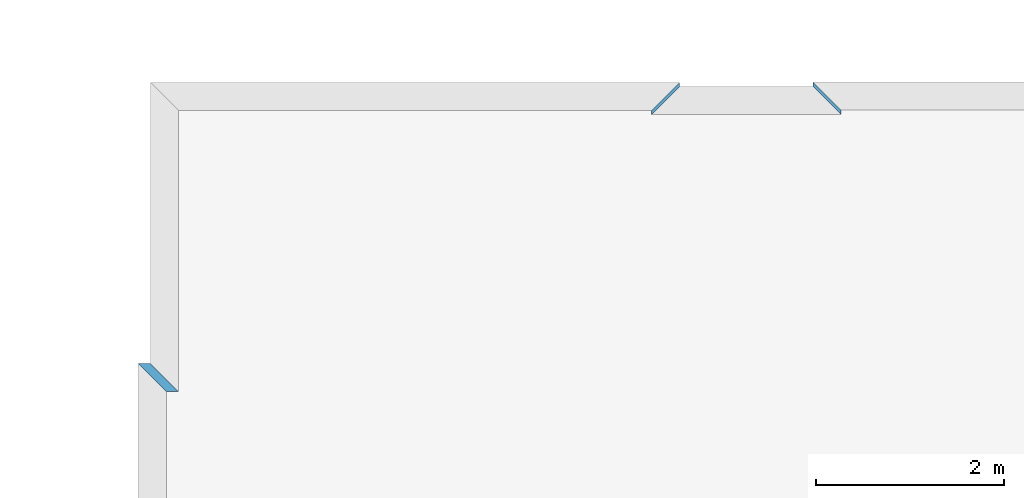
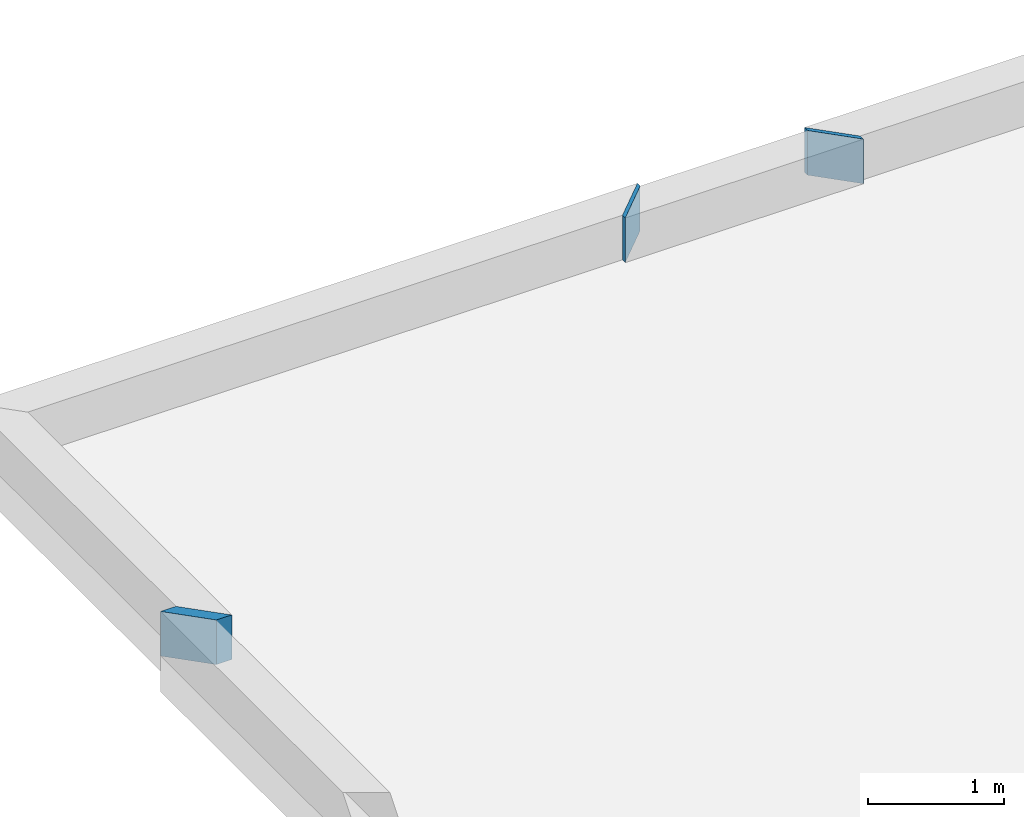
# One storey, part 8 of 72: 3 walls.
"""IFC2X3 building model written with IfcOpenShell, lengths in metres."""

from ifc_helpers import new_model, entity, si_unit, converted_unit, derived_unit, frame, origin_with_axes, place, context, project, spatial, polyline, outline, extrude, material, layer, layer_set, layer_usage, element, save


model = new_model("IFC2X3")

# Units and contexts
context_of_model_1 = context(None, 3, world=origin_with_axes())
context_of_model_2 = context(None, 3, world=origin_with_axes())
context_of_model_3 = context(None, 2, world=origin_with_axes())
context_of_model_4 = context(None, 3, world=origin_with_axes())
ifc_project = project(units=[si_unit("LENGTHUNIT", "METRE"), si_unit("AREAUNIT", "SQUARE_METRE"), si_unit("ELECTRICCURRENTUNIT", "AMPERE"), si_unit("ELECTRICVOLTAGEUNIT", "VOLT"), si_unit("ELECTRICRESISTANCEUNIT", "OHM"), si_unit("POWERUNIT", "WATT"), si_unit("MASSUNIT", "GRAM"), si_unit("SOLIDANGLEUNIT", "STERADIAN"), si_unit("THERMODYNAMICTEMPERATUREUNIT", "KELVIN"), si_unit("PRESSUREUNIT", "PASCAL"), si_unit("LUMINOUSFLUXUNIT", "LUMEN"), si_unit("ILLUMINANCEUNIT", "LUX"), si_unit("FREQUENCYUNIT", "HERTZ"), si_unit("VOLUMEUNIT", "CUBIC_METRE"), si_unit("TIMEUNIT", "SECOND"), derived_unit("VOLUMETRICFLOWRATEUNIT", [(si_unit("TIMEUNIT", "SECOND"), -1), (si_unit("VOLUMEUNIT", "CUBIC_METRE"), 1)]), derived_unit("THERMALTRANSMITTANCEUNIT", [(si_unit("AREAUNIT", "SQUARE_METRE"), -1), (si_unit("THERMODYNAMICTEMPERATUREUNIT", "KELVIN"), -1), (si_unit("POWERUNIT", "WATT"), 1)]), converted_unit("PLANEANGLEUNIT", "DEGREE", entity("IfcPlaneAngleMeasure", 57.29577951308232), si_unit("PLANEANGLEUNIT", "RADIAN"), dimensions=[0, 0, 0, 0, 0, 0, 0])], contexts=[context_of_model_1, context_of_model_2, context_of_model_3, context_of_model_4])

# Site, building, storey
site = spatial("IfcSite", under=ifc_project, CompositionType="ELEMENT")
building_placement = place(None, origin_with_axes())
building = spatial("IfcBuilding", under=site, at=building_placement, Name="200", CompositionType="ELEMENT")
storey_placement = place(building_placement, frame((0.0, 0.0, 15.68000030517578), z_axis=(0.0, 0.0, 1.0), x_axis=(1.0, 0.0, 0.0)))
storey = spatial("IfcBuildingStorey", under=building, at=storey_placement, Name="3.etasje", CompositionType="ELEMENT", Elevation=15.68000030517578)

# Walls
ifc_material = material(Name="Layer-YV3 30 cm")
ifc_layer = layer(ifc_material, 0.300000011920929, ventilated=False)
ifc_layer_set = layer_set([ifc_layer])
ifc_layer_usage = layer_usage(ifc_layer_set, "AXIS2", "POSITIVE", 0.0)
wall_1_placement = place(storey_placement, frame((-49.9124870300293, 2.602568864822388, 0.0), z_axis=(0.0, 0.0, 1.0), x_axis=(-4.371138828673793e-08, -1.0, 0.0)))
element("IfcWallStandardCase", 1, at=wall_1_placement, inside=storey, material=ifc_layer_usage, Name="YV3 30 cm", context=context_of_model_1, shape_type="SweptSolid", body=[
    extrude(outline(polyline([(0.0, 0.0), (0.04630017280578617, 4.135903062765138e-25), (0.346300125122031, 0.2999992370605857), (0.2999999523162449, 0.2999992370605857), (0.0, 0.0)])), frame((0.0, 0.0, 0.0), z_axis=(0.0, 0.0, 1.0), x_axis=(0.9999999999999991, 4.371125962649911e-08, 0.0)), (0.0, 0.0, 1.0), 0.4),
])
wall_2_placement = place(storey_placement, frame((-51.33248138427734, 2.556268930435181, 0.0), z_axis=(0.0, 0.0, 1.0), x_axis=(-4.371138828673793e-08, 1.0, 0.0)))
element("IfcWallStandardCase", 2, at=wall_2_placement, inside=storey, material=ifc_layer_usage, Name="YV3 30 cm", context=context_of_model_1, shape_type="SweptSolid", body=[
    extrude(outline(polyline([(0.0, 0.0), (0.04141402244567875, -2.067951531382569e-25), (-0.2585859298706013, 0.2999992370605507), (-0.2999999523162801, 0.2999992370605507), (0.0, 0.0)])), frame((0.0, 0.0, 0.0), z_axis=(0.0, 0.0, 1.0), x_axis=(0.999999999999999, -4.371137677160384e-08, 0.0)), (0.0, 0.0, 1.0), 0.4),
])
wall_3_placement = place(storey_placement, frame((-56.97746658325195, -0.4006710946559906, 0.0), z_axis=(0.0, 0.0, 1.0), x_axis=(-1.0, -8.742277657347586e-08, 0.0)))
element("IfcWallStandardCase", 3, at=wall_3_placement, inside=storey, material=ifc_layer_usage, Name="YV3 30 cm", context=context_of_model_1, shape_type="SweptSolid", body=[
    extrude(outline(polyline([(0.0, 0.0), (0.1308784484863286, 0.0), (-0.1691207885742231, 0.2999999821186066), (-0.2999992370605518, 0.2999999821186065), (0.0, 0.0)])), frame((0.0, 0.0, 0.0), z_axis=(0.0, 0.0, 1.0), x_axis=(0.9999999999999962, -8.742278007803823e-08, 0.0)), (0.0, 0.0, 1.0), 0.4),
])

save(model, "model.ifc")
